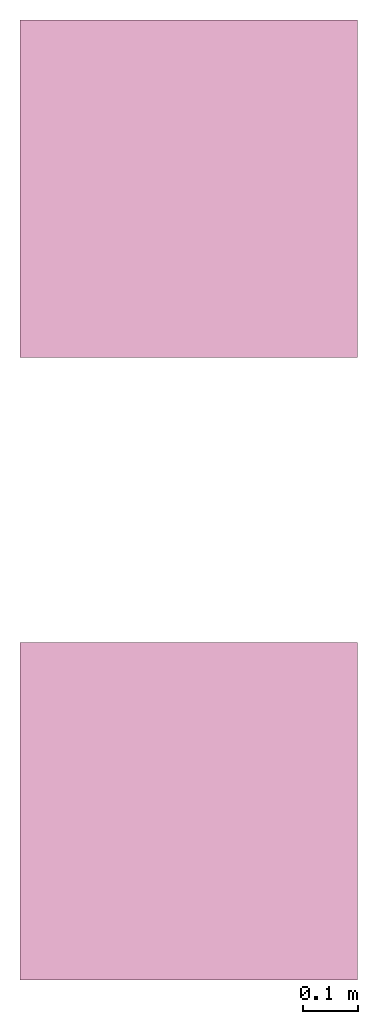
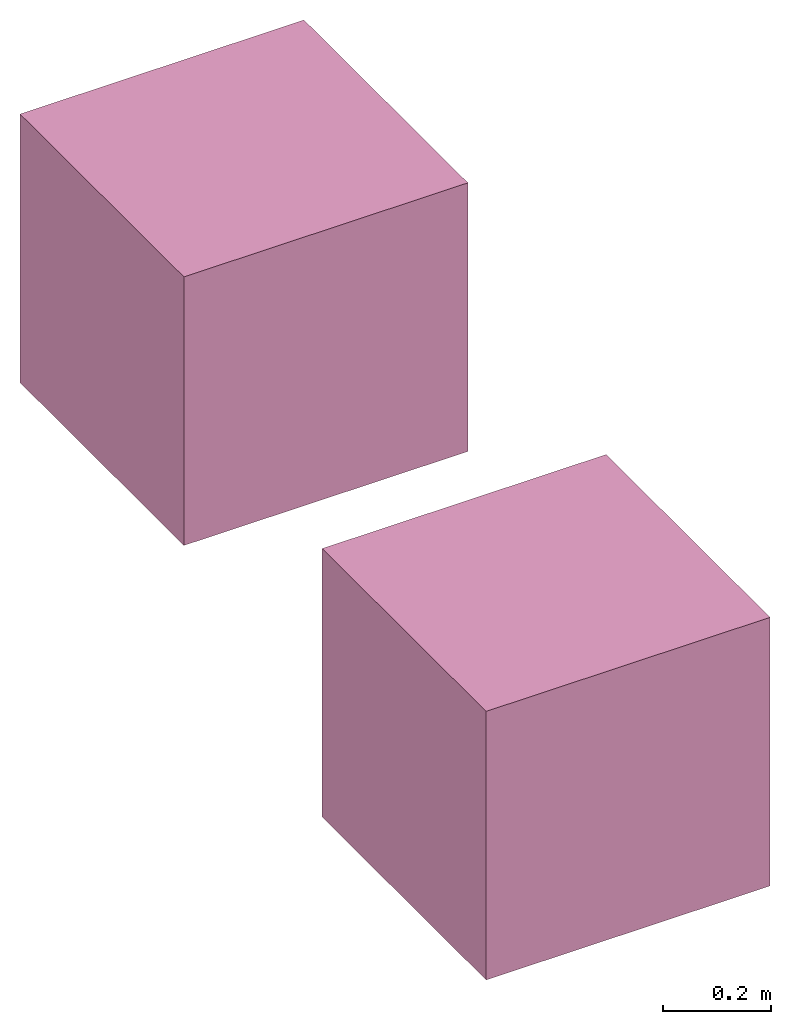
# One storey: 2 furniture elements.
"""IFC4 building model written with IfcOpenShell, lengths in feet."""

from ifc_helpers import new_model, entity, si_unit, converted_unit, frame, origin_with_axes, origin_2d_with_axis, place, context, subcontext, project, spatial, polygons, source, transform, mapped, type_object, type_shapes, element, save


model = new_model("IFC4")

# Units and contexts
model_context = context("Model", 3, precision=1e-05, world=origin_with_axes())
plan_context = context("Plan", 2, precision=1e-05, world=origin_2d_with_axis())
body_context = subcontext(model_context, "Body", "Model", "MODEL_VIEW")
ifc_project = project(units=[converted_unit("LENGTHUNIT", "foot", entity("IfcReal", 0.3048), si_unit("LENGTHUNIT", "METRE"), dimensions=[1, 0, 0, 0, 0, 0, 0]), converted_unit("VOLUMEUNIT", "cubic foot", entity("IfcReal", 0.0283168467116885), si_unit("VOLUMEUNIT", "CUBIC_METRE"), dimensions=[3, 0, 0, 0, 0, 0, 0]), converted_unit("PLANEANGLEUNIT", "degree", entity("IfcReal", 0.0174532925199433), si_unit("PLANEANGLEUNIT", "RADIAN"), dimensions=[0, 0, 0, 0, 0, 0, 0]), converted_unit("AREAUNIT", "square foot", entity("IfcReal", 0.09290304), si_unit("AREAUNIT", "SQUARE_METRE"), dimensions=[2, 0, 0, 0, 0, 0, 0])], contexts=[model_context, plan_context])

# Site, building, storey
site_placement = place(None, origin_with_axes())
site = spatial("IfcSite", under=ifc_project, at=site_placement)
building_placement = place(site_placement, origin_with_axes())
building = spatial("IfcBuilding", under=site, at=building_placement, Name="Building")
storey_placement = place(building_placement, origin_with_axes())
storey = spatial("IfcBuildingStorey", under=building, at=storey_placement, Name="Storey")

# Furniture
furniture_type = type_object("IfcFurnitureType", Name="Cube", AssemblyPlace="NOTDEFINED", PredefinedType="CHAIR")
shared_shape = source(origin_with_axes(), body_context, "Body", "Tessellation", [
    polygons([(-1.0, -1.0, -1.0), (-1.0, -1.0, 1.0), (-1.0, 1.0, -1.0), (-1.0, 1.0, 1.0), (1.0, -1.0, -1.0), (1.0, -1.0, 1.0), (1.0, 1.0, -1.0), (1.0, 1.0, 1.0)], [[[1, 2, 4, 3]], [[3, 4, 8, 7]], [[7, 8, 6, 5]], [[5, 6, 2, 1]], [[3, 7, 5, 1]], [[8, 4, 2, 6]]], closed=True),
])
type_shapes(furniture_type, [shared_shape])
furniture_1_placement = place(storey_placement, frame((0.0, 3.68643346733934, 1.00000001235897), z_axis=(0.0, 0.0, 1.0), x_axis=(1.0, 0.0, 0.0)))
element("IfcFurniture", 1, at=furniture_1_placement, inside=storey, type_object=furniture_type, Name="Furniture", context=body_context, shape_type="MappedRepresentation", body=[
    mapped(shared_shape, transform((0.0, 0.0, 0.0), x_axis=(1.0, 0.0, 0.0), y_axis=(0.0, 1.0, 0.0), z_axis=(0.0, 0.0, 1.0), scale=1.0)),
])
furniture_2_placement = place(storey_placement, origin_with_axes())
element("IfcFurniture", 2, at=furniture_2_placement, inside=storey, Name="Cube", PredefinedType="CHAIR", context=body_context, shape_type="Tessellation", body=[
    polygons([(-1.0, -1.0, -1.0), (-1.0, -1.0, 1.0), (-1.0, 1.0, -1.0), (-1.0, 1.0, 1.0), (1.0, -1.0, -1.0), (1.0, -1.0, 1.0), (1.0, 1.0, -1.0), (1.0, 1.0, 1.0)], [[[1, 2, 4, 3]], [[3, 4, 8, 7]], [[7, 8, 6, 5]], [[5, 6, 2, 1]], [[3, 7, 5, 1]], [[8, 4, 2, 6]]], closed=True),
])

save(model, "model.ifc")
